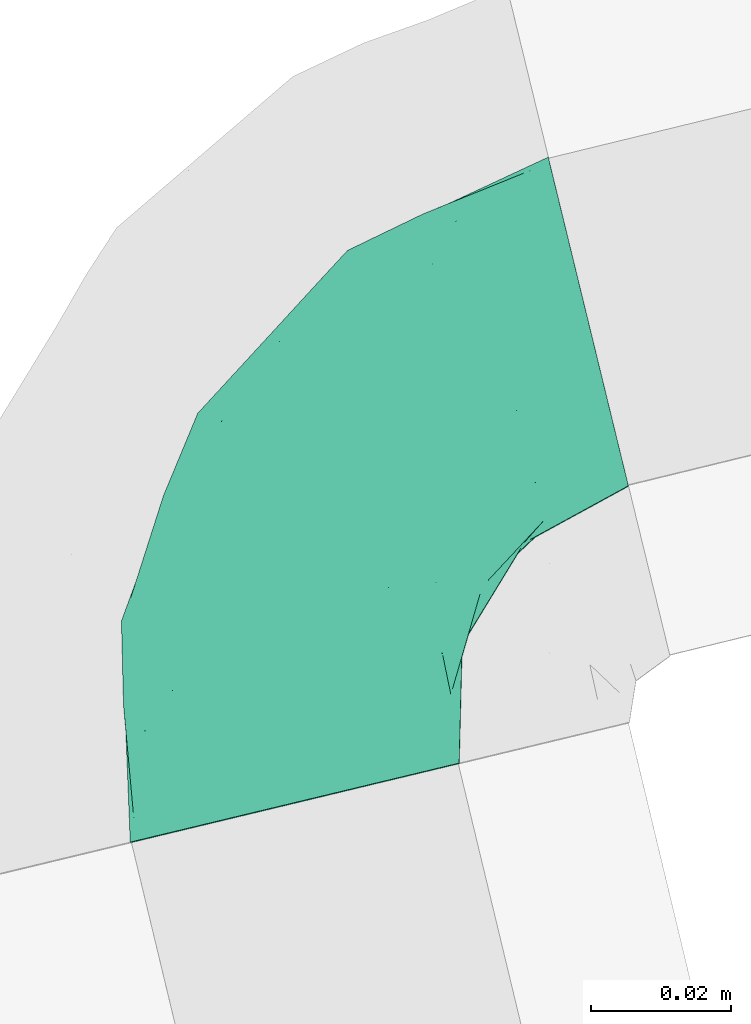
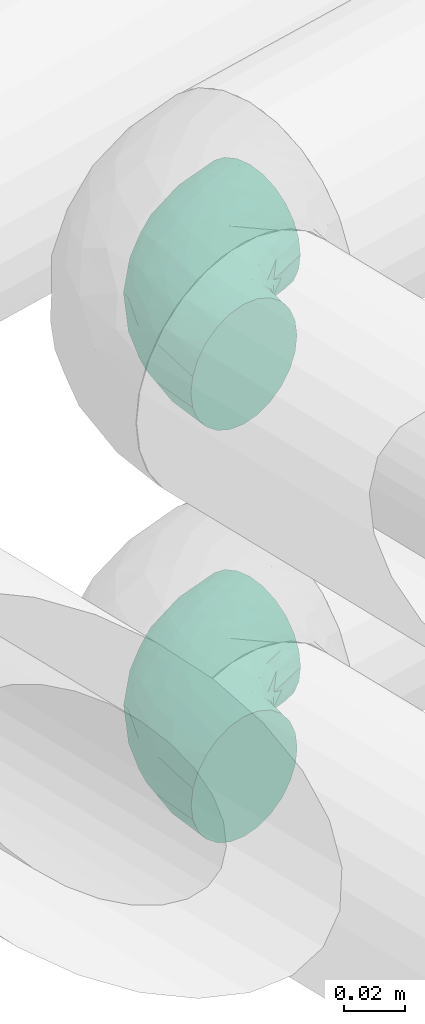
# One storey, part 84 of 93: 2 flow fittings.
"""IFC2X3 building model written with IfcOpenShell, lengths in millimetres."""

from ifc_helpers import new_model, entity, si_unit, converted_unit, derived_unit, direction, frame, origin, place, context, subcontext, project, spatial, faceted_brep, source, transform, mapped, material, type_object, type_shapes, element, save


model = new_model("IFC2X3")

# Units and contexts
model_context = context("Model", 3, precision=0.01, world=origin(), true_north=direction((6.12303176911189e-17, 1.0)))
body_context = subcontext(model_context, "Body", "Model", "MODEL_VIEW")
ifc_project = project(units=[si_unit("LENGTHUNIT", "METRE", prefix="MILLI"), si_unit("AREAUNIT", "SQUARE_METRE"), si_unit("VOLUMEUNIT", "CUBIC_METRE"), converted_unit("PLANEANGLEUNIT", "DEGREE", entity("IfcRatioMeasure", 0.0174532925199433), si_unit("PLANEANGLEUNIT", "RADIAN"), dimensions=[0, 0, 0, 0, 0, 0, 0]), si_unit("MASSUNIT", "GRAM", prefix="KILO"), derived_unit("MASSDENSITYUNIT", [(si_unit("MASSUNIT", "GRAM", prefix="KILO"), 1), (si_unit("LENGTHUNIT", "METRE"), -3)]), derived_unit("MOMENTOFINERTIAUNIT", [(si_unit("LENGTHUNIT", "METRE"), 4)]), si_unit("TIMEUNIT", "SECOND"), si_unit("FREQUENCYUNIT", "HERTZ"), si_unit("THERMODYNAMICTEMPERATUREUNIT", "DEGREE_CELSIUS"), derived_unit("THERMALTRANSMITTANCEUNIT", [(si_unit("MASSUNIT", "GRAM", prefix="KILO"), 1), (si_unit("THERMODYNAMICTEMPERATUREUNIT", "KELVIN"), -1), (si_unit("TIMEUNIT", "SECOND"), -3)]), derived_unit("VOLUMETRICFLOWRATEUNIT", [(si_unit("LENGTHUNIT", "METRE"), 3), (si_unit("TIMEUNIT", "SECOND"), -1)]), derived_unit("MASSFLOWRATEUNIT", [(si_unit("MASSUNIT", "GRAM", prefix="KILO"), 1), (si_unit("TIMEUNIT", "SECOND"), -1)]), derived_unit("ROTATIONALFREQUENCYUNIT", [(si_unit("TIMEUNIT", "SECOND"), -1)]), si_unit("ELECTRICCURRENTUNIT", "AMPERE"), si_unit("ELECTRICVOLTAGEUNIT", "VOLT"), si_unit("POWERUNIT", "WATT"), si_unit("FORCEUNIT", "NEWTON", prefix="KILO"), si_unit("ILLUMINANCEUNIT", "LUX"), si_unit("LUMINOUSFLUXUNIT", "LUMEN"), si_unit("LUMINOUSINTENSITYUNIT", "CANDELA"), derived_unit("USERDEFINED", [(si_unit("MASSUNIT", "GRAM", prefix="KILO"), -1), (si_unit("LENGTHUNIT", "METRE"), -2), (si_unit("TIMEUNIT", "SECOND"), 3), (si_unit("LUMINOUSFLUXUNIT", "LUMEN"), 1)]), derived_unit("LINEARVELOCITYUNIT", [(si_unit("LENGTHUNIT", "METRE"), 1), (si_unit("TIMEUNIT", "SECOND"), -1)]), si_unit("PRESSUREUNIT", "PASCAL"), derived_unit("USERDEFINED", [(si_unit("LENGTHUNIT", "METRE"), -2), (si_unit("MASSUNIT", "GRAM", prefix="KILO"), 1), (si_unit("TIMEUNIT", "SECOND"), -2)]), derived_unit("LINEARFORCEUNIT", [(si_unit("MASSUNIT", "GRAM", prefix="KILO"), 1), (si_unit("LENGTHUNIT", "METRE"), 1), (si_unit("TIMEUNIT", "SECOND"), -2), (si_unit("LENGTHUNIT", "METRE"), -1)]), derived_unit("PLANARFORCEUNIT", [(si_unit("MASSUNIT", "GRAM", prefix="KILO"), 1), (si_unit("LENGTHUNIT", "METRE"), 1), (si_unit("TIMEUNIT", "SECOND"), -2), (si_unit("LENGTHUNIT", "METRE"), -2)])], contexts=[model_context])

# Site, building, storey
site_placement = place(None, origin())
site = spatial("IfcSite", under=ifc_project, at=site_placement, CompositionType="ELEMENT")
building_placement = place(site_placement, origin())
building = spatial("IfcBuilding", under=site, at=building_placement, CompositionType="ELEMENT")
storey_placement = place(building_placement, frame((0.0, 0.0, -4200.0)))
storey = spatial("IfcBuildingStorey", under=building, at=storey_placement, CompositionType="ELEMENT", Elevation=-4200.0)

# Flow fittings
ifc_material = material()
pipe_fitting_type_1 = type_object("IfcPipeFittingType", Name="ADSK_1", PredefinedType="NOTDEFINED", material=ifc_material)
shared_shape_1 = source(origin(), body_context, "Body", "Brep", [
    faceted_brep([(-56.81, 12.07, -20.91), (-56.81, 6.25, -23.33), (-56.81, 0.0, -24.15), (-56.81, -6.25, -23.33), (-56.81, -12.08, -20.91), (-56.81, -17.08, -17.08), (-56.81, -20.91, -12.08), (-56.81, -23.33, -6.25), (-56.81, -24.15, 0.0), (-56.81, -23.33, 6.25), (-56.81, -20.91, 12.07), (-56.81, -17.08, 17.08), (-56.81, -12.08, 20.91), (-56.81, -6.25, 23.33), (-56.81, 0.0, 24.15), (-56.81, 6.25, 23.33), (-56.81, 12.07, 20.91), (-56.81, 17.08, 17.08), (-56.81, 20.91, 12.07), (-56.81, 23.33, 6.25), (-56.81, 24.15, 0.0), (-56.81, 23.33, -6.25), (-56.81, 20.91, -12.08), (-56.81, 17.08, -17.08), (0.19, 56.81, -24.15), (-6.06, 56.83, -23.33), (-11.89, 56.85, -20.91), (-16.89, 56.87, -17.08), (-20.73, 56.88, -12.08), (-23.14, 56.89, -6.25), (-23.96, 56.89, 0.0), (-23.14, 56.89, 6.25), (-20.73, 56.88, 12.07), (-16.89, 56.87, 17.08), (-11.89, 56.85, 20.91), (-6.06, 56.83, 23.33), (0.19, 56.81, 24.15), (6.44, 56.79, 23.33), (12.26, 56.77, 20.91), (17.26, 56.76, 17.08), (21.1, 56.74, 12.07), (23.51, 56.74, 6.25), (24.34, 56.73, 0.0), (23.51, 56.74, -6.25), (21.1, 56.74, -12.08), (17.26, 56.76, -17.08), (12.26, 56.77, -20.91), (6.44, 56.79, -23.33), (20.63, 37.46, 7.75), (15.97, 22.8, 5.91), (18.08, 25.76, 0.0), (-41.32, -21.07, 0.0), (-41.73, -18.38, 13.72), (-24.44, -13.6, 12.49), (-37.17, -13.24, 18.15), (-6.57, -4.88, 8.21), (-21.55, -15.18, 6.21), (-12.67, -9.24, 0.0), (-37.53, -20.51, 7.75), (-7.29, 7.31, 20.25), (-23.24, -4.29, 20.43), (-11.79, -3.22, 15.88), (-41.96, -8.7, 21.82), (13.36, 37.13, 18.15), (9.45, 23.37, 16.85), (4.36, 23.22, 20.43), (2.85, 10.83, 15.59), (-29.32, 0.9, 23.52), (-43.96, 20.56, 15.69), (-39.1, 26.31, 10.87), (-48.86, 22.92, 9.95), (-34.45, 23.82, 17.17), (-15.67, 6.79, 22.82), (-8.57, 20.34, 23.88), (-18.03, 12.85, 24.09), (-48.13, 14.92, 19.65), (-43.9, -2.85, 23.78), (-9.07, 48.82, 22.58), (-3.64, 42.58, 24.07), (-40.17, 4.26, 24.09), (-43.88, 26.12, 5.46), (-43.86, 9.88, 22.74), (-4.82, 16.79, 22.52), (-2.61, 1.41, 12.53), (8.02, 9.8, 6.74), (6.0, 10.29, 11.43), (-25.35, 40.89, 10.71), (18.52, 41.67, 13.72), (13.68, 24.39, 12.49), (-30.39, 31.93, 12.64), (-26.9, 31.02, 16.77), (2.99, 43.89, 23.78), (8.83, 41.93, 21.82), (21.21, 41.25, 0.0), (-25.13, 47.1, 4.05), (-33.11, 33.22, 5.86), (-28.4, 40.51, 0.0), (-40.42, 28.53, 0.0), (-15.55, 43.83, 19.9), (-20.12, 45.11, 15.61), (-25.82, -18.0, 0.0), (-11.15, 38.23, 22.91), (-9.87, 27.8, 24.09), (-20.01, 30.19, 21.25), (-23.89, -9.27, 17.15), (-31.1, 11.72, 23.64), (-28.63, 7.22, 24.15), (-29.41, 18.02, 22.27), (-28.3, 24.16, 20.02), (-37.42, 17.68, 20.25), (-15.75, 29.17, 22.99), (-20.7, 20.77, 23.43), (-0.8, 29.33, 23.52), (-13.31, -7.65, 12.06), (0.47, -0.48, 0.0), (9.28, 12.64, 0.0), (-37.17, -13.24, -18.15), (15.74, 22.92, -6.86), (8.02, 9.8, -6.74), (-45.04, 20.27, -15.61), (-43.78, 15.7, -19.9), (-38.19, 11.27, -22.91), (-48.79, 9.23, -22.58), (-47.02, 25.28, -4.05), (-33.11, 33.22, -5.86), (18.52, 41.67, -13.72), (-30.13, 20.11, -21.25), (2.99, 43.89, -23.78), (-4.13, 40.19, -24.09), (-40.8, 25.48, -10.71), (-41.73, -18.38, -13.72), (-37.53, -20.51, -7.75), (-11.62, 31.14, -23.64), (-7.13, 28.65, -24.15), (-12.79, 18.07, -24.09), (-31.83, 30.5, -12.64), (-30.93, 27.0, -16.77), (-43.9, -2.85, -23.78), (-6.74, 15.69, -22.82), (-20.31, 8.64, -23.88), (-24.44, -13.6, -12.49), (-42.56, 3.78, -24.07), (-17.92, 29.47, -22.27), (-24.07, 28.38, -20.02), (-27.76, 9.96, -24.09), (-25.98, 43.97, -5.46), (8.83, 41.93, -21.82), (-9.74, 43.89, -22.74), (-20.42, 44.03, -15.69), (-21.55, -15.18, -6.21), (-13.31, -7.65, -12.06), (-23.99, -9.78, -16.74), (-11.79, -3.22, -15.88), (-14.76, 48.18, -19.65), (-23.24, -4.29, -20.43), (4.36, 23.22, -20.43), (-0.8, 29.33, -23.52), (-26.18, 39.18, -10.87), (-23.71, 34.52, -17.17), (13.36, 37.13, -18.15), (-41.96, -8.7, -21.82), (-22.76, 48.93, -9.95), (13.68, 24.39, -12.49), (20.63, 37.46, -7.75), (-16.78, 4.88, -22.52), (6.0, 10.29, -11.43), (9.32, 23.34, -16.94), (-17.56, 37.47, -20.25), (-29.12, 15.85, -22.99), (-20.7, 20.77, -23.43), (-29.32, 0.9, -23.52), (-7.29, 7.31, -20.25), (2.85, 10.83, -15.59), (-6.57, -4.88, -8.21), (-2.61, 1.41, -12.53)], [[[0, 1, 2, 3, 4, 5, 6, 7, 8, 9, 10, 11, 12, 13, 14, 15, 16, 17, 18, 19, 20, 21, 22, 23]], [[24, 25, 26, 27, 28, 29, 30, 31, 32, 33, 34, 35, 36, 37, 38, 39, 40, 41, 42, 43, 44, 45, 46, 47]], [[48, 49, 50]], [[9, 8, 51]], [[52, 53, 54]], [[55, 56, 57]], [[10, 58, 52]], [[9, 58, 10]], [[59, 60, 61]], [[54, 12, 11]], [[54, 62, 12]], [[63, 39, 38]], [[64, 65, 66]], [[62, 60, 67]], [[68, 69, 70]], [[71, 69, 68]], [[72, 73, 74]], [[16, 75, 17]], [[13, 76, 14]], [[35, 77, 78]], [[14, 79, 15]], [[17, 68, 18]], [[14, 76, 79]], [[20, 19, 80]], [[70, 19, 18]], [[81, 15, 79]], [[15, 81, 16]], [[73, 72, 82]], [[83, 84, 85]], [[32, 31, 86]], [[48, 87, 88]], [[89, 90, 86]], [[12, 62, 13]], [[36, 91, 37]], [[48, 41, 40]], [[36, 35, 78]], [[63, 92, 65]], [[40, 39, 87]], [[93, 41, 48]], [[87, 48, 40]], [[92, 38, 37]], [[48, 50, 93]], [[94, 31, 30]], [[49, 88, 84]], [[80, 69, 95]], [[95, 96, 97]], [[10, 52, 11]], [[96, 94, 30]], [[90, 98, 99]], [[80, 95, 97]], [[56, 58, 100]], [[99, 98, 33]], [[101, 102, 78]], [[103, 101, 98]], [[9, 51, 58]], [[77, 98, 101]], [[77, 35, 34]], [[34, 33, 98]], [[104, 60, 54]], [[92, 63, 38]], [[105, 106, 74]], [[107, 103, 108]], [[107, 81, 105]], [[75, 68, 17]], [[109, 108, 71]], [[33, 32, 99]], [[110, 103, 111]], [[101, 110, 102]], [[91, 78, 112]], [[53, 52, 58]], [[54, 11, 52]], [[60, 62, 54]], [[100, 58, 51]], [[76, 62, 67]], [[53, 113, 104]], [[60, 59, 72]], [[39, 63, 87]], [[88, 87, 63]], [[91, 92, 37]], [[42, 41, 93]], [[112, 82, 65]], [[112, 65, 92]], [[65, 59, 66]], [[105, 81, 79]], [[75, 81, 109]], [[32, 86, 99]], [[90, 99, 86]], [[98, 90, 103]], [[107, 108, 109]], [[74, 102, 111]], [[112, 78, 102]], [[74, 111, 105]], [[74, 67, 72]], [[61, 104, 113]], [[66, 59, 61]], [[56, 53, 58]], [[84, 55, 114]], [[61, 113, 83]], [[66, 88, 64]], [[78, 91, 36]], [[92, 91, 112]], [[62, 76, 13]], [[79, 76, 67]], [[89, 95, 69]], [[94, 95, 86]], [[84, 114, 115]], [[83, 85, 66]], [[105, 79, 106]], [[107, 105, 111]], [[20, 80, 97]], [[70, 80, 19]], [[103, 107, 111]], [[81, 107, 109]], [[103, 90, 108]], [[71, 108, 90]], [[71, 90, 89]], [[109, 71, 68]], [[95, 94, 96]], [[86, 31, 94]], [[79, 67, 106]], [[67, 74, 106]], [[57, 114, 55]], [[113, 56, 55]], [[56, 100, 57]], [[60, 72, 67]], [[82, 72, 59]], [[65, 82, 59]], [[82, 112, 73]], [[112, 102, 73]], [[102, 74, 73]], [[81, 75, 16]], [[68, 75, 109]], [[68, 70, 18]], [[80, 70, 69]], [[98, 77, 34]], [[78, 77, 101]], [[95, 89, 86]], [[71, 89, 69]], [[102, 110, 111]], [[101, 103, 110]], [[53, 104, 54]], [[61, 60, 104]], [[56, 113, 53]], [[83, 113, 55]], [[84, 83, 55]], [[61, 83, 66]], [[84, 88, 85]], [[88, 66, 85]], [[88, 63, 64]], [[65, 64, 63]], [[88, 49, 48]], [[49, 115, 50]], [[115, 49, 84]], [[116, 5, 4]], [[117, 115, 118]], [[119, 120, 23]], [[121, 122, 120]], [[97, 123, 20]], [[0, 23, 120]], [[124, 97, 96]], [[125, 45, 44]], [[121, 120, 126]], [[24, 127, 128]], [[22, 21, 129]], [[0, 122, 1]], [[5, 116, 130]], [[123, 21, 20]], [[131, 100, 51]], [[132, 133, 134]], [[6, 5, 130]], [[135, 136, 129]], [[137, 3, 2]], [[138, 139, 134]], [[6, 131, 7]], [[131, 130, 140]], [[141, 2, 1]], [[142, 126, 143]], [[121, 144, 141]], [[136, 120, 119]], [[96, 145, 124]], [[46, 146, 47]], [[30, 29, 145]], [[147, 25, 128]], [[27, 148, 28]], [[131, 149, 100]], [[150, 151, 152]], [[27, 26, 153]], [[147, 26, 25]], [[151, 154, 152]], [[24, 47, 127]], [[1, 122, 141]], [[146, 155, 156]], [[157, 148, 158]], [[24, 128, 25]], [[46, 159, 146]], [[160, 116, 4]], [[145, 157, 124]], [[148, 157, 161]], [[150, 140, 151]], [[45, 125, 159]], [[159, 46, 45]], [[125, 162, 159]], [[116, 160, 154]], [[42, 93, 43]], [[51, 7, 131]], [[160, 4, 3]], [[43, 163, 44]], [[43, 93, 163]], [[139, 138, 164]], [[117, 118, 165]], [[161, 29, 28]], [[166, 155, 159]], [[149, 131, 140]], [[142, 147, 132]], [[153, 148, 27]], [[167, 143, 158]], [[23, 22, 119]], [[168, 126, 169]], [[121, 168, 144]], [[137, 141, 170]], [[140, 130, 116]], [[8, 7, 51]], [[131, 6, 130]], [[137, 160, 3]], [[170, 164, 154]], [[170, 154, 160]], [[154, 171, 152]], [[44, 163, 125]], [[50, 163, 93]], [[162, 125, 163]], [[155, 146, 159]], [[127, 146, 156]], [[166, 162, 172]], [[155, 171, 138]], [[132, 147, 128]], [[153, 147, 167]], [[22, 129, 119]], [[136, 119, 129]], [[120, 136, 126]], [[142, 143, 167]], [[134, 144, 169]], [[170, 141, 144]], [[134, 169, 132]], [[134, 156, 138]], [[171, 172, 152]], [[173, 118, 114]], [[150, 174, 173]], [[173, 57, 149]], [[155, 172, 171]], [[165, 118, 174]], [[141, 137, 2]], [[160, 137, 170]], [[146, 127, 47]], [[128, 127, 156]], [[135, 124, 157]], [[123, 124, 129]], [[118, 173, 174]], [[162, 163, 117]], [[132, 128, 133]], [[142, 132, 169]], [[30, 145, 96]], [[161, 145, 29]], [[126, 142, 169]], [[147, 142, 167]], [[126, 136, 143]], [[158, 143, 136]], [[158, 136, 135]], [[167, 158, 148]], [[124, 123, 97]], [[129, 21, 123]], [[128, 156, 133]], [[156, 134, 133]], [[150, 149, 140]], [[155, 138, 156]], [[57, 173, 114]], [[57, 100, 149]], [[164, 138, 171]], [[154, 164, 171]], [[164, 170, 139]], [[170, 144, 139]], [[144, 134, 139]], [[147, 153, 26]], [[148, 153, 167]], [[148, 161, 28]], [[145, 161, 157]], [[120, 122, 0]], [[141, 122, 121]], [[124, 135, 129]], [[158, 135, 157]], [[144, 168, 169]], [[121, 126, 168]], [[140, 116, 151]], [[154, 151, 116]], [[174, 152, 172]], [[149, 150, 173]], [[152, 174, 150]], [[174, 172, 165]], [[172, 162, 165]], [[117, 165, 162]], [[162, 166, 159]], [[172, 155, 166]], [[163, 50, 117]], [[115, 117, 50]], [[115, 114, 118]]]),
])
type_shapes(pipe_fitting_type_1, [shared_shape_1])
flow_fitting_1_placement = place(storey_placement, frame((-14964.13, 11345.58, 2558.8), z_axis=(0.0, 0.0, 1.0), x_axis=(-0.971551074149835, -0.236830129667453, 0.0)))
element("IfcFlowFitting", 1, at=flow_fitting_1_placement, inside=storey, type_object=pipe_fitting_type_1, material=ifc_material, Name="ADSK_1", ObjectType="ADSK_1", context=body_context, shape_type="MappedRepresentation", body=[
    mapped(shared_shape_1, transform((0.0, 0.0, 0.0), scale=1.0)),
])
pipe_fitting_type_2 = type_object("IfcPipeFittingType", Name="ADSK_1", PredefinedType="NOTDEFINED", material=ifc_material)
shared_shape_2 = source(origin(), body_context, "Body", "Brep", [
    faceted_brep([(-56.83, 12.07, -20.91), (-56.83, 6.25, -23.33), (-56.83, 0.0, -24.15), (-56.83, -6.25, -23.33), (-56.83, -12.08, -20.91), (-56.83, -17.08, -17.08), (-56.83, -20.91, -12.08), (-56.83, -23.33, -6.25), (-56.83, -24.15, 0.0), (-56.83, -23.33, 6.25), (-56.83, -20.91, 12.07), (-56.83, -17.08, 17.08), (-56.83, -12.08, 20.91), (-56.83, -6.25, 23.33), (-56.83, 0.0, 24.15), (-56.83, 6.25, 23.33), (-56.83, 12.07, 20.91), (-56.83, 17.08, 17.08), (-56.83, 20.91, 12.07), (-56.83, 23.33, 6.25), (-56.83, 24.15, 0.0), (-56.83, 23.33, -6.25), (-56.83, 20.91, -12.08), (-56.83, 17.08, -17.08), (0.17, 56.83, -24.15), (-6.08, 56.85, -23.33), (-11.9, 56.86, -20.91), (-16.9, 56.88, -17.08), (-20.74, 56.89, -12.08), (-23.15, 56.9, -6.25), (-23.98, 56.9, 0.0), (-23.15, 56.9, 6.25), (-20.74, 56.89, 12.07), (-16.9, 56.88, 17.08), (-11.9, 56.86, 20.91), (-6.08, 56.85, 23.33), (0.17, 56.83, 24.15), (6.42, 56.81, 23.33), (12.25, 56.79, 20.91), (17.25, 56.77, 17.08), (21.09, 56.76, 12.07), (23.5, 56.76, 6.25), (24.32, 56.75, 0.0), (23.5, 56.76, -6.25), (21.09, 56.76, -12.08), (17.25, 56.77, -17.08), (12.25, 56.79, -20.91), (6.42, 56.81, -23.33), (20.62, 37.48, 7.75), (15.96, 22.81, 5.91), (18.08, 25.77, 0.0), (-41.33, -21.07, 0.0), (-41.74, -18.38, 13.72), (-24.45, -13.6, 12.49), (-37.19, -13.24, 18.15), (-6.58, -4.88, 8.21), (-21.56, -15.18, 6.21), (-12.68, -9.23, 0.0), (-37.54, -20.51, 7.75), (-7.3, 7.32, 20.25), (-23.25, -4.29, 20.43), (-11.79, -3.22, 15.88), (-41.97, -8.7, 21.82), (13.35, 37.15, 18.15), (9.44, 23.39, 16.85), (4.36, 23.23, 20.43), (2.85, 10.83, 15.59), (-29.33, 0.9, 23.52), (-43.97, 20.56, 15.69), (-39.11, 26.31, 10.88), (-48.87, 22.92, 9.95), (-34.45, 23.82, 17.17), (-15.68, 6.79, 22.82), (-8.58, 20.35, 23.88), (-18.04, 12.86, 24.09), (-48.14, 14.92, 19.65), (-43.91, -2.85, 23.78), (-9.08, 48.83, 22.58), (-3.65, 42.59, 24.07), (-40.18, 4.26, 24.09), (-43.89, 26.12, 5.46), (-43.87, 9.88, 22.74), (-4.83, 16.8, 22.52), (-2.62, 1.41, 12.53), (8.01, 9.81, 6.74), (5.98, 10.29, 11.43), (-25.36, 40.89, 10.71), (18.51, 41.69, 13.72), (13.68, 24.41, 12.49), (-30.4, 31.93, 12.64), (-26.91, 31.03, 16.77), (2.98, 43.91, 23.78), (8.82, 41.94, 21.82), (21.2, 41.26, 0.0), (-25.14, 47.11, 4.05), (-33.12, 33.23, 5.86), (-28.41, 40.52, 0.0), (-40.43, 28.53, 0.0), (-15.56, 43.84, 19.9), (-20.13, 45.11, 15.61), (-25.83, -18.0, 0.0), (-11.16, 38.23, 22.91), (-9.88, 27.8, 24.09), (-20.02, 30.2, 21.25), (-23.9, -9.27, 17.15), (-31.11, 11.73, 23.64), (-28.63, 7.22, 24.15), (-29.42, 18.02, 22.27), (-28.31, 24.17, 20.02), (-37.43, 17.68, 20.25), (-15.76, 29.17, 22.99), (-20.71, 20.77, 23.43), (-0.81, 29.33, 23.52), (-13.32, -7.65, 12.06), (0.47, -0.47, 0.0), (9.27, 12.65, 0.0), (-37.19, -13.24, -18.15), (15.73, 22.93, -6.86), (8.01, 9.81, -6.74), (-45.05, 20.27, -15.61), (-43.79, 15.7, -19.9), (-38.2, 11.27, -22.91), (-48.8, 9.23, -22.58), (-47.03, 25.29, -4.05), (-33.12, 33.23, -5.86), (18.51, 41.69, -13.72), (-30.14, 20.11, -21.25), (2.98, 43.91, -23.78), (-4.14, 40.2, -24.09), (-40.81, 25.48, -10.71), (-41.74, -18.38, -13.72), (-37.54, -20.51, -7.75), (-11.63, 31.15, -23.64), (-7.14, 28.66, -24.15), (-12.8, 18.08, -24.09), (-31.84, 30.5, -12.64), (-30.94, 27.01, -16.77), (-43.91, -2.85, -23.78), (-6.74, 15.7, -22.82), (-20.32, 8.64, -23.88), (-24.45, -13.6, -12.49), (-42.58, 3.78, -24.07), (-17.93, 29.48, -22.27), (-24.08, 28.38, -20.02), (-27.77, 9.96, -24.09), (-25.99, 43.97, -5.46), (8.82, 41.94, -21.82), (-9.75, 43.9, -22.74), (-20.43, 44.03, -15.69), (-21.56, -15.18, -6.21), (-13.32, -7.65, -12.06), (-24.0, -9.78, -16.74), (-11.79, -3.22, -15.88), (-14.78, 48.19, -19.65), (-23.25, -4.29, -20.43), (4.36, 23.23, -20.43), (-0.81, 29.33, -23.52), (-26.19, 39.19, -10.88), (-23.72, 34.53, -17.17), (13.35, 37.15, -18.15), (-41.97, -8.7, -21.82), (-22.77, 48.94, -9.95), (13.68, 24.41, -12.49), (20.62, 37.48, -7.75), (-16.78, 4.88, -22.52), (5.98, 10.29, -11.43), (9.32, 23.35, -16.94), (-17.57, 37.48, -20.25), (-29.13, 15.85, -22.99), (-29.33, 0.9, -23.52), (-7.3, 7.32, -20.25), (2.85, 10.83, -15.59), (-20.71, 20.77, -23.43), (-6.58, -4.88, -8.21), (-2.62, 1.41, -12.53)], [[[0, 1, 2, 3, 4, 5, 6, 7, 8, 9, 10, 11, 12, 13, 14, 15, 16, 17, 18, 19, 20, 21, 22, 23]], [[24, 25, 26, 27, 28, 29, 30, 31, 32, 33, 34, 35, 36, 37, 38, 39, 40, 41, 42, 43, 44, 45, 46, 47]], [[48, 49, 50]], [[9, 8, 51]], [[52, 53, 54]], [[55, 56, 57]], [[10, 58, 52]], [[9, 58, 10]], [[59, 60, 61]], [[54, 12, 11]], [[54, 62, 12]], [[63, 39, 38]], [[64, 65, 66]], [[62, 60, 67]], [[68, 69, 70]], [[71, 69, 68]], [[72, 73, 74]], [[16, 75, 17]], [[13, 76, 14]], [[35, 77, 78]], [[14, 79, 15]], [[17, 68, 18]], [[14, 76, 79]], [[20, 19, 80]], [[70, 19, 18]], [[81, 15, 79]], [[15, 81, 16]], [[73, 72, 82]], [[83, 84, 85]], [[32, 31, 86]], [[48, 87, 88]], [[89, 90, 86]], [[12, 62, 13]], [[36, 91, 37]], [[48, 41, 40]], [[36, 35, 78]], [[63, 92, 65]], [[40, 39, 87]], [[93, 41, 48]], [[87, 48, 40]], [[92, 38, 37]], [[48, 50, 93]], [[94, 31, 30]], [[49, 88, 84]], [[80, 69, 95]], [[95, 96, 97]], [[10, 52, 11]], [[96, 94, 30]], [[90, 98, 99]], [[80, 95, 97]], [[56, 58, 100]], [[99, 98, 33]], [[101, 102, 78]], [[103, 101, 98]], [[9, 51, 58]], [[77, 98, 101]], [[77, 35, 34]], [[34, 33, 98]], [[104, 60, 54]], [[92, 63, 38]], [[105, 106, 74]], [[107, 103, 108]], [[107, 81, 105]], [[75, 68, 17]], [[109, 108, 71]], [[33, 32, 99]], [[110, 103, 111]], [[101, 110, 102]], [[91, 78, 112]], [[53, 52, 58]], [[54, 11, 52]], [[60, 62, 54]], [[100, 58, 51]], [[76, 62, 67]], [[53, 113, 104]], [[60, 59, 72]], [[39, 63, 87]], [[88, 87, 63]], [[91, 92, 37]], [[42, 41, 93]], [[112, 82, 65]], [[112, 65, 92]], [[65, 59, 66]], [[105, 81, 79]], [[75, 81, 109]], [[32, 86, 99]], [[90, 99, 86]], [[98, 90, 103]], [[107, 108, 109]], [[74, 102, 111]], [[112, 78, 102]], [[74, 111, 105]], [[74, 67, 72]], [[61, 104, 113]], [[66, 59, 61]], [[56, 53, 58]], [[84, 55, 114]], [[61, 113, 83]], [[66, 88, 64]], [[78, 91, 36]], [[92, 91, 112]], [[62, 76, 13]], [[79, 76, 67]], [[89, 95, 69]], [[94, 95, 86]], [[84, 114, 115]], [[83, 85, 66]], [[105, 79, 106]], [[107, 105, 111]], [[20, 80, 97]], [[70, 80, 19]], [[103, 107, 111]], [[81, 107, 109]], [[103, 90, 108]], [[71, 108, 90]], [[71, 90, 89]], [[109, 71, 68]], [[95, 94, 96]], [[86, 31, 94]], [[79, 67, 106]], [[67, 74, 106]], [[57, 114, 55]], [[113, 56, 55]], [[56, 100, 57]], [[60, 72, 67]], [[82, 72, 59]], [[65, 82, 59]], [[82, 112, 73]], [[112, 102, 73]], [[102, 74, 73]], [[81, 75, 16]], [[68, 75, 109]], [[68, 70, 18]], [[80, 70, 69]], [[98, 77, 34]], [[78, 77, 101]], [[95, 89, 86]], [[71, 89, 69]], [[102, 110, 111]], [[101, 103, 110]], [[53, 104, 54]], [[61, 60, 104]], [[56, 113, 53]], [[83, 113, 55]], [[84, 83, 55]], [[61, 83, 66]], [[84, 88, 85]], [[88, 66, 85]], [[88, 63, 64]], [[65, 64, 63]], [[88, 49, 48]], [[49, 115, 50]], [[115, 49, 84]], [[116, 5, 4]], [[117, 115, 118]], [[119, 120, 23]], [[121, 122, 120]], [[97, 123, 20]], [[0, 23, 120]], [[124, 97, 96]], [[125, 45, 44]], [[121, 120, 126]], [[24, 127, 128]], [[22, 21, 129]], [[0, 122, 1]], [[5, 116, 130]], [[123, 21, 20]], [[131, 100, 51]], [[132, 133, 134]], [[6, 5, 130]], [[135, 136, 129]], [[137, 3, 2]], [[138, 139, 134]], [[6, 131, 7]], [[131, 130, 140]], [[141, 2, 1]], [[142, 126, 143]], [[121, 144, 141]], [[136, 120, 119]], [[96, 145, 124]], [[46, 146, 47]], [[30, 29, 145]], [[147, 25, 128]], [[27, 148, 28]], [[131, 149, 100]], [[150, 151, 152]], [[27, 26, 153]], [[147, 26, 25]], [[151, 154, 152]], [[24, 47, 127]], [[1, 122, 141]], [[146, 155, 156]], [[157, 148, 158]], [[24, 128, 25]], [[46, 159, 146]], [[160, 116, 4]], [[145, 157, 124]], [[148, 157, 161]], [[150, 140, 151]], [[45, 125, 159]], [[159, 46, 45]], [[125, 162, 159]], [[116, 160, 154]], [[42, 93, 43]], [[51, 7, 131]], [[160, 4, 3]], [[43, 163, 44]], [[43, 93, 163]], [[139, 138, 164]], [[117, 118, 165]], [[161, 29, 28]], [[166, 155, 159]], [[149, 131, 140]], [[142, 147, 132]], [[153, 148, 27]], [[167, 143, 158]], [[23, 22, 119]], [[121, 126, 168]], [[121, 168, 144]], [[137, 141, 169]], [[140, 130, 116]], [[8, 7, 51]], [[131, 6, 130]], [[137, 160, 3]], [[169, 164, 154]], [[169, 154, 160]], [[154, 170, 152]], [[44, 163, 125]], [[50, 163, 93]], [[162, 125, 163]], [[155, 146, 159]], [[127, 146, 156]], [[166, 162, 171]], [[155, 170, 138]], [[132, 147, 128]], [[153, 147, 167]], [[22, 129, 119]], [[136, 119, 129]], [[120, 136, 126]], [[142, 143, 167]], [[134, 144, 172]], [[169, 141, 144]], [[134, 172, 132]], [[134, 156, 138]], [[170, 171, 152]], [[173, 118, 114]], [[150, 174, 173]], [[173, 57, 149]], [[155, 171, 170]], [[165, 118, 174]], [[141, 137, 2]], [[160, 137, 169]], [[146, 127, 47]], [[128, 127, 156]], [[135, 124, 157]], [[123, 124, 129]], [[118, 173, 174]], [[162, 163, 117]], [[132, 128, 133]], [[142, 132, 172]], [[30, 145, 96]], [[161, 145, 29]], [[126, 142, 172]], [[147, 142, 167]], [[126, 136, 143]], [[158, 143, 136]], [[158, 136, 135]], [[167, 158, 148]], [[124, 123, 97]], [[129, 21, 123]], [[128, 156, 133]], [[156, 134, 133]], [[150, 149, 140]], [[155, 138, 156]], [[57, 173, 114]], [[57, 100, 149]], [[164, 138, 170]], [[154, 164, 170]], [[164, 169, 139]], [[169, 144, 139]], [[144, 134, 139]], [[147, 153, 26]], [[148, 153, 167]], [[148, 161, 28]], [[145, 161, 157]], [[120, 122, 0]], [[141, 122, 121]], [[124, 135, 129]], [[158, 135, 157]], [[126, 172, 168]], [[144, 168, 172]], [[140, 116, 151]], [[154, 151, 116]], [[174, 152, 171]], [[149, 150, 173]], [[152, 174, 150]], [[174, 171, 165]], [[171, 162, 165]], [[117, 165, 162]], [[162, 166, 159]], [[171, 155, 166]], [[163, 50, 117]], [[115, 117, 50]], [[115, 114, 118]]]),
])
type_shapes(pipe_fitting_type_2, [shared_shape_2])
flow_fitting_2_placement = place(storey_placement, frame((-14964.12, 11345.49, 2392.84), z_axis=(0.0, 0.0, 1.0), x_axis=(-0.971551074149835, -0.23683012966745, 0.0)))
element("IfcFlowFitting", 2, at=flow_fitting_2_placement, inside=storey, type_object=pipe_fitting_type_2, material=ifc_material, Name="ADSK_1", ObjectType="ADSK_1", context=body_context, shape_type="MappedRepresentation", body=[
    mapped(shared_shape_2, transform((0.0, 0.0, 0.0), scale=1.0)),
])

save(model, "model.ifc")
